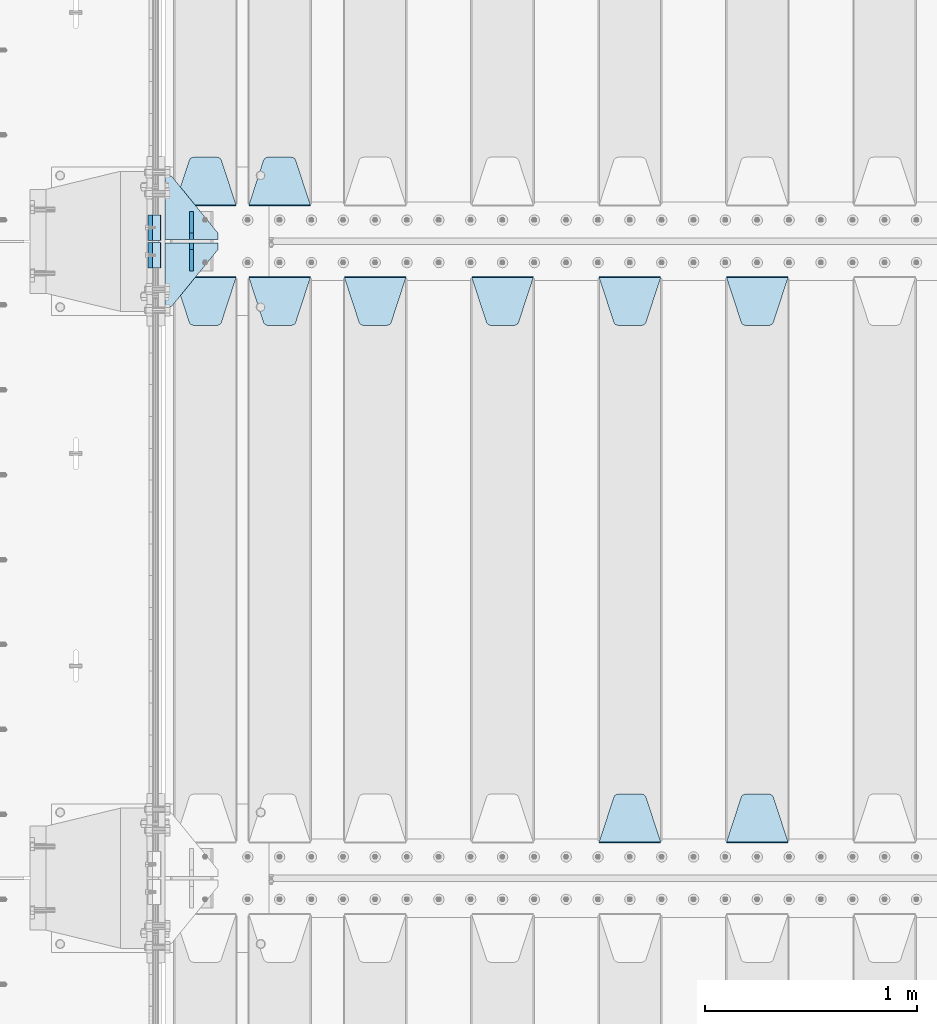
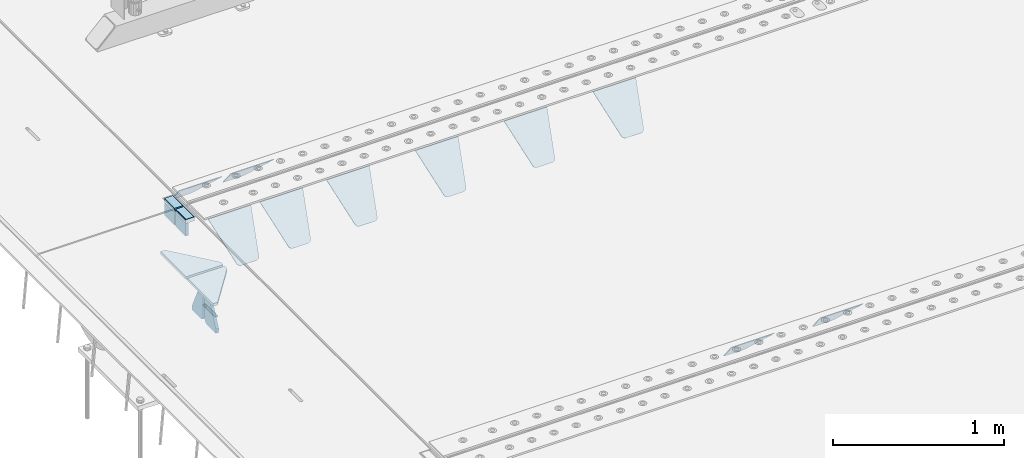
# One storey, part 178 of 219: 18 plates.
"""IFC2X3 building model written with IfcOpenShell, lengths in millimetres."""

import ifcopenshell
import ifcopenshell.guid

model = None  # the IFC model being written
_history = None  # IfcOwnerHistory: only IFC2X3 demands one
_inside = {}  # id of a spatial element -> (the spatial element, [elements in it])
_under = {}  # id of a project, library or spatial element -> (it, [spatial elements below it])
_declared = {}  # id of a project -> (the project, [libraries it declares])
_typed = {}  # id of a type object -> (the type object, [elements of that type])
_made_of = {}  # id of a material, layer set ... -> (it, [elements and type objects made of it])


def new_model(schema):
    """Start an empty IFC model of exactly this schema.

    Asked for "IFC4X3", IfcOpenShell would pick the latest addendum, in which some entities
    have other attributes; the version numbers below select the first issue.
    IFC2X3 requires an IfcOwnerHistory on every rooted entity: one is made here for all.
    """
    global model, _history
    if schema == "IFC4X3":
        model = ifcopenshell.file(schema_version=(4, 3, 0, 0))
    else:
        model = ifcopenshell.file(schema=schema)
    _inside.clear()
    _under.clear()
    _declared.clear()
    _typed.clear()
    _made_of.clear()
    _history = None
    if model.schema == "IFC2X3":
        org = make("IfcOrganization", Name="unknown")
        user = make(
            "IfcPersonAndOrganization",
            ThePerson=make("IfcPerson", FamilyName="unknown"),
            TheOrganization=org,
        )
        app = make(
            "IfcApplication",
            ApplicationDeveloper=org,
            Version="unknown",
            ApplicationFullName="unknown",
            ApplicationIdentifier="unknown",
        )
        _history = make(
            "IfcOwnerHistory",
            OwningUser=user,
            OwningApplication=app,
            ChangeAction="ADDED",
            CreationDate=0,
        )
    return model


def make(cls, **values):
    """One entity of the class cls with the attributes given. An attribute that is None is left unset."""
    return model.create_entity(
        cls, **{name: value for name, value in values.items() if value is not None}
    )


def rooted(cls, **values):
    """An entity with a GlobalId (a new one), such as an element, a storey or a relation."""
    return make(cls, GlobalId=ifcopenshell.guid.new(), OwnerHistory=_history, **values)


def si_unit(unit_type, name, prefix=None):
    """IfcSIUnit, for example si_unit("LENGTHUNIT", "METRE", prefix="MILLI")."""
    return make("IfcSIUnit", UnitType=unit_type, Prefix=prefix, Name=name)


def assignment(units):
    """IfcUnitAssignment: the units of a project."""
    return None if units is None else make("IfcUnitAssignment", Units=units)


def point(xyz):
    """IfcCartesianPoint."""
    return None if xyz is None else make("IfcCartesianPoint", Coordinates=xyz)


def direction(xyz):
    """IfcDirection."""
    return None if xyz is None else make("IfcDirection", DirectionRatios=xyz)


def frame(location, z_axis=None, x_axis=None):
    """IfcAxis2Placement3D, a coordinate frame: its origin and axes. An axis left out is left unset."""
    return make(
        "IfcAxis2Placement3D",
        Location=point(location),
        Axis=direction(z_axis),
        RefDirection=direction(x_axis),
    )


def origin_with_axes():
    """The frame at (0, 0, 0) with the z axis (0, 0, 1) and the x axis (1, 0, 0) written out."""
    return frame((0.0, 0.0, 0.0), z_axis=(0.0, 0.0, 1.0), x_axis=(1.0, 0.0, 0.0))


def place(relative_to, where):
    """IfcLocalPlacement: puts the frame where relative to a parent placement (None: the world)."""
    return make(
        "IfcLocalPlacement", PlacementRelTo=relative_to, RelativePlacement=where
    )


def context(
    kind, dimensions, precision=None, world=None, true_north=None, identifier=None
):
    """IfcGeometricRepresentationContext, for example the 3D "Model" context."""
    return make(
        "IfcGeometricRepresentationContext",
        ContextIdentifier=identifier,
        ContextType=kind,
        CoordinateSpaceDimension=dimensions,
        Precision=precision,
        WorldCoordinateSystem=world,
        TrueNorth=true_north,
    )


def subcontext(parent, identifier, kind, view, scale=None):
    """IfcGeometricRepresentationSubContext, for example "Body" below "Model"."""
    return make(
        "IfcGeometricRepresentationSubContext",
        ContextIdentifier=identifier,
        ContextType=kind,
        ParentContext=parent,
        TargetScale=scale,
        TargetView=view,
    )


def project(units=None, contexts=None):
    """IfcProject with its units and contexts."""
    return rooted(
        "IfcProject",
        Name="project",
        RepresentationContexts=contexts,
        UnitsInContext=assignment(units),
    )


def spatial(cls, under=None, at=None, **own):
    """A site, building, storey or space (cls), placed at a placement, below another one or the project."""
    s = rooted(cls, ObjectPlacement=at, **own)
    if under is not None:
        _under.setdefault(under.id(), (under, []))[1].append(s)
    return s


def faces_of(points, faces, orient=None, outer=None):
    """IfcFace entities. A face is a list of loops; a loop is a list of indices into points, from 0.

    orient and outer hold one flag for each loop. By default every Orientation is true, the
    first loop of a face is its IfcFaceOuterBound and the others are IfcFaceBound.
    """
    made = []
    for i, loops in enumerate(faces):
        bounds = []
        for j, loop in enumerate(loops):
            is_outer = j == 0 if outer is None else outer[i][j]
            bounds.append(
                make(
                    "IfcFaceOuterBound" if is_outer else "IfcFaceBound",
                    Bound=make("IfcPolyLoop", Polygon=[points[k] for k in loop]),
                    Orientation=True if orient is None else orient[i][j],
                )
            )
        made.append(make("IfcFace", Bounds=bounds))
    return made


def faceted_brep(points, faces, orient=None, outer=None, voids=None):
    """IfcFacetedBrep: a solid bounded by flat faces; with voids (closed shells), ...WithVoids."""
    shared = [point(p) for p in points]
    hull = make("IfcClosedShell", CfsFaces=faces_of(shared, faces, orient, outer))
    if voids is None:
        return make("IfcFacetedBrep", Outer=hull)
    return make(
        "IfcFacetedBrepWithVoids",
        Outer=hull,
        Voids=[
            make(cls, CfsFaces=faces_of(shared, fs, o, b)) for cls, fs, o, b in voids
        ],
    )


def shape(context_of_items, identifier, shape_type, items):
    """IfcShapeRepresentation: the items that make up one representation, for example the "Body"."""
    return make(
        "IfcShapeRepresentation",
        ContextOfItems=context_of_items,
        RepresentationIdentifier=identifier,
        RepresentationType=shape_type,
        Items=items,
    )


def material(Name=None, Category=None):
    """IfcMaterial."""
    return make("IfcMaterial", Name=Name, Category=Category)


def made_of(thing, what):
    """Note that an element or type object is made of a material, layer set ...; save() writes the relation."""
    if what is not None:
        _made_of.setdefault(what.id(), (what, []))[1].append(thing)
    return thing


def type_object(cls, material=None, **own):
    """A type object (cls), such as IfcWallType, which elements share."""
    return made_of(rooted(cls, **own), material)


def element(
    cls,
    number,
    at=None,
    inside=None,
    cuts=None,
    type_object=None,
    material=None,
    context=None,
    identifier="Body",
    shape_type=None,
    held_by="IfcProductDefinitionShape",
    body=None,
    shapes=None,
    **own,
):
    """One element of the class cls, such as IfcWall. Its Tag is "e" and its number.

    at: its placement. inside: the storey or other place that contains it. cuts: it is an
    opening in that element (IfcRelVoidsElement). A single representation is given by context,
    identifier, shape_type and body (its items); several are given by shapes. held_by: the class
    of the entity that holds the representations. save() writes the other relations.
    """
    e = rooted(cls, Tag="e%d" % number, ObjectPlacement=at, **own)
    if body is not None:
        shapes = [shape(context, identifier, shape_type, body)]
    if shapes is not None:
        e.Representation = make(held_by, Representations=shapes)
    if inside is not None:
        _inside.setdefault(inside.id(), (inside, []))[1].append(e)
    if cuts is not None:
        rooted(
            "IfcRelVoidsElement", RelatingBuildingElement=cuts, RelatedOpeningElement=e
        )
    if type_object is not None:
        _typed.setdefault(type_object.id(), (type_object, []))[1].append(e)
    return made_of(e, material)


def aggregate(whole, parts):
    """IfcRelAggregates: a whole, such as a stair, and the parts it consists of."""
    return rooted("IfcRelAggregates", RelatingObject=whole, RelatedObjects=parts)


def save(model, path):
    """Write the relations noted so far, then the file.

    IfcRelAggregates (storeys below a building ...), IfcRelContainedInSpatialStructure (elements
    in a storey), IfcRelDefinesByType, IfcRelAssociatesMaterial and IfcRelDeclares: one each for
    every whole, place, type object, material and project.
    """
    for whole, parts in _under.values():
        aggregate(whole, parts)
    for where, things in _inside.values():
        rooted(
            "IfcRelContainedInSpatialStructure",
            RelatedElements=things,
            RelatingStructure=where,
        )
    for kind, things in _typed.values():
        rooted("IfcRelDefinesByType", RelatedObjects=things, RelatingType=kind)
    for what, things in _made_of.values():
        rooted("IfcRelAssociatesMaterial", RelatedObjects=things, RelatingMaterial=what)
    for by, libraries in _declared.values():
        rooted("IfcRelDeclares", RelatingContext=by, RelatedDefinitions=libraries)
    model.write(path)


model = new_model("IFC2X3")

# Units and contexts
model_context = context("Model", 3, precision=1e-05, world=origin_with_axes())
body_context = subcontext(model_context, "Body", "Model", "MODEL_VIEW")
ifc_project = project(units=[si_unit("LENGTHUNIT", "METRE", prefix="MILLI"), si_unit("AREAUNIT", "SQUARE_METRE"), si_unit("VOLUMEUNIT", "CUBIC_METRE"), si_unit("MASSUNIT", "GRAM", prefix="KILO"), si_unit("TIMEUNIT", "SECOND"), si_unit("PLANEANGLEUNIT", "RADIAN"), si_unit("SOLIDANGLEUNIT", "STERADIAN"), si_unit("THERMODYNAMICTEMPERATUREUNIT", "DEGREE_CELSIUS"), si_unit("LUMINOUSINTENSITYUNIT", "LUMEN")], contexts=[model_context])

# Site, building, storey
site_placement = place(None, origin_with_axes())
site = spatial("IfcSite", under=ifc_project, at=site_placement, CompositionType="ELEMENT")
building_placement = place(site_placement, origin_with_axes())
building = spatial("IfcBuilding", under=site, at=building_placement, Name="Standard", CompositionType="ELEMENT")
storey_placement = place(building_placement, origin_with_axes())
storey = spatial("IfcBuildingStorey", under=building, at=storey_placement, Name="Undefined", CompositionType="ELEMENT", Elevation=0.0)

# Plates
ifc_material_1 = material()
plate_type_1 = type_object("IfcPlateType", PredefinedType="NOTDEFINED")
for number, where, z_axis, x_axis in (
    (1, (-9.99999993997335, 29935.0000004336, -16.000386849525), (-1.0, 0.0, 0.0), (0.0, -4.95099997756316e-06, 0.999999999987744)),
    (2, (-10.0000000600267, 30065.0000004319, -15.9997432191214), (-1.0, 0.0, 0.0), (0.0, -4.95099997756316e-06, 0.999999999987744)),
):
    element("IfcPlate", number, at=place(storey_placement, frame(where, z_axis=z_axis, x_axis=x_axis)), inside=storey, type_object=plate_type_1, material=ifc_material_1, context=body_context, shape_type="Brep", body=[
        faceted_brep([(0.0, -60.0, 0.0), (-0.000933120085687023, -60.0000000000036, 60.0), (-0.000933120085687023, 59.9999999999964, 60.0), (0.0, 60.0000000000036, 0.0), (24.9991450303709, -60.0, 60.0), (24.9991450303709, 59.9999999999964, 60.0), (26.544215218168, -60.0000000000036, 59.7552873850884), (26.544215218168, 60.0, 59.7552873850884), (27.9380461396139, -60.0000000000036, 59.0451032459123), (27.9380461396139, 60.0, 59.0451032459123), (29.0442025908961, -60.0000000000036, 57.9389639895784), (29.0442025908961, 60.0, 57.9389639895784), (29.7544083969366, -60.0, 56.5451441080361), (29.7544083969366, 60.0000000000036, 56.5451441080361), (29.9991450297669, -60.0000000000036, 55.0000777244568), (29.9991450297669, 60.0, 55.0000777244568), (29.999922274335, -60.0, 5.00007772445704), (29.999922274335, 60.0, 5.00007772445704), (29.7552240705896, -60.0000000000036, 3.45497416452589), (29.7552240705896, 60.0, 3.45497416452589), (29.0450346578116, -60.0, 2.06111146690959), (29.0450346578116, 59.9999999999964, 2.06111146690959), (27.9388736885072, -60.0, 0.954933302319514), (27.9388736885072, 59.9999999999964, 0.954933302319514), (26.5450220308766, -60.0000000000036, 0.244722222183089), (26.5450220308766, 60.0, 0.244722222183089), (24.9999222749392, -60.0, 2.64677169070637e-13), (24.9999222749392, 60.0, 2.66453525910038e-13)], [[[0, 1, 2, 3]], [[1, 4, 5, 2]], [[4, 6, 7, 5]], [[6, 8, 9, 7]], [[8, 10, 11, 9]], [[10, 12, 13, 11]], [[12, 14, 15, 13]], [[14, 16, 17, 15]], [[16, 18, 19, 17]], [[18, 20, 21, 19]], [[20, 22, 23, 21]], [[22, 24, 25, 23]], [[24, 26, 27, 25]], [[26, 0, 3, 27]], [[5, 7, 9, 11, 13, 15, 17, 19, 21, 23, 25, 27, 3, 2]], [[26, 24, 22, 20, 18, 16, 14, 12, 10, 8, 6, 4, 1, 0]]]),
    ])
ifc_material_2 = material(Name="STEEL/S355N")
plate_type_2 = type_object("IfcPlateType", PredefinedType="NOTDEFINED")
for number, where, z_axis, x_axis in (
    (3, (-60.0, 29995.0004459832, -106.000711879208), (0.0, -0.999999999987744, -4.95099999993769e-06), (0.0, -4.95099997756316e-06, 0.999999999987744)),
    (4, (-60.0, 30125.0004459814, -106.000068249326), (0.0, -0.999999999987744, -4.95099999993769e-06), (0.0, -4.95099997756316e-06, 0.999999999987744)),
):
    element("IfcPlate", number, at=place(storey_placement, frame(where, z_axis=z_axis, x_axis=x_axis)), inside=storey, type_object=plate_type_2, material=ifc_material_2, context=body_context, shape_type="Brep", body=[
        faceted_brep([(0.0, -10.0, 0.0), (4.30816271546064e-10, -10.0, 120.000000000004), (4.30816271546064e-10, 10.0, 120.000000000004), (0.0, 10.0, 0.0), (89.9999999999979, -10.0, 120.000000000004), (89.9999999999979, 10.0, 120.000000000004), (90.0, -10.0, 1.09139364212751e-11), (90.0, 10.0, 1.09139364212751e-11)], [[[0, 1, 2, 3]], [[1, 4, 5, 2]], [[4, 6, 7, 5]], [[6, 0, 3, 7]], [[5, 7, 3, 2]], [[6, 4, 1, 0]]]),
    ])
plate_type_3 = type_object("IfcPlateType", PredefinedType="NOTDEFINED")
plate_1_placement = place(storey_placement, frame((2655.0, 29831.767766956, -1.76776695296758), z_axis=(0.0, -0.707106781186547, -0.707106781186548), x_axis=(1.0, 0.0, 0.0)))
element("IfcPlate", 5, at=plate_1_placement, inside=storey, type_object=plate_type_3, material=ifc_material_2, context=body_context, shape_type="Brep", body=[
    faceted_brep([(0.0, -2.5, 0.0), (69.345504679477, -2.5, 300.171731424834), (69.345504679477, 2.49999999999636, 300.171731424831), (0.0, 2.5, 0.0), (70.9274061199576, -2.50000000000364, 304.8974424154), (70.9274061199576, 2.49999999999636, 304.8974424154), (73.3818627772307, -2.50000000000364, 309.234538108532), (73.3818627772307, 2.49999999999636, 309.234538108532), (76.6187032999569, -2.50000000000364, 313.023683126106), (76.6187032999569, 2.49999999999636, 313.023683126106), (80.5190132704993, -2.50000000000364, 316.125672595372), (80.5190132704993, 2.49999999999636, 316.125672595372), (84.9395038596831, -2.50000000000364, 318.426546230476), (84.9395038596831, 2.5, 318.426546230479), (89.7177759439237, -2.50000000000364, 319.841774983277), (89.7177759439237, 2.5, 319.841774983281), (94.6782862926502, -2.50000000000364, 320.319366455078), (94.6782862926502, 2.49999999999636, 320.319366455078), (195.32171370735, -2.50000000000364, 320.319366455078), (195.32171370735, 2.49999999999636, 320.319366455078), (200.282224056076, -2.50000000000364, 319.841774983277), (200.282224056076, 2.5, 319.841774983281), (205.060496140317, -2.50000000000364, 318.426546230476), (205.060496140317, 2.49999999999636, 318.426546230476), (209.480986729501, -2.50000000000364, 316.125672595372), (209.480986729501, 2.49999999999636, 316.125672595372), (213.381296700043, -2.50000000000364, 313.023683126106), (213.381296700043, 2.49999999999272, 313.023683126106), (216.618137222769, -2.50000000000364, 309.234538108529), (216.618137222769, 2.49999999999636, 309.234538108525), (219.072593880042, -2.50000000000364, 304.8974424154), (219.072593880042, 2.49999999999636, 304.8974424154), (220.654495320523, -2.5, 300.171731424834), (220.654495320523, 2.49999999999636, 300.171731424831), (290.0, -2.50000000000364, 3.63797880709171e-12), (290.0, 2.49999999999636, 0.0)], [[[0, 1, 2, 3]], [[1, 4, 5, 2]], [[4, 6, 7, 5]], [[6, 8, 9, 7]], [[8, 10, 11, 9]], [[10, 12, 13, 11]], [[12, 14, 15, 13]], [[14, 16, 17, 15]], [[16, 18, 19, 17]], [[18, 20, 21, 19]], [[20, 22, 23, 21]], [[22, 24, 25, 23]], [[24, 26, 27, 25]], [[26, 28, 29, 27]], [[28, 30, 31, 29]], [[30, 32, 33, 31]], [[32, 34, 35, 33]], [[34, 0, 3, 35]], [[5, 7, 9, 11, 13, 15, 17, 19, 21, 23, 25, 27, 29, 31, 33, 35, 3, 2]], [[34, 32, 30, 28, 26, 24, 22, 20, 18, 16, 14, 12, 10, 8, 6, 4, 1, 0]]]),
])
plate_2_placement = place(storey_placement, frame((2945.0, 27168.232233047, -1.76776695296758), z_axis=(0.0, 0.707106781186547, -0.707106781186548), x_axis=(-1.0, 0.0, 0.0)))
element("IfcPlate", 6, at=plate_2_placement, inside=storey, type_object=plate_type_3, material=ifc_material_2, context=body_context, shape_type="Brep", body=[
    faceted_brep([(0.0, -2.5, 0.0), (69.345504679477, -2.5, 300.171731424834), (69.345504679477, 2.49999999999636, 300.171731424831), (0.0, 2.5, 0.0), (70.9274061199576, -2.50000000000364, 304.8974424154), (70.9274061199576, 2.49999999999636, 304.8974424154), (73.3818627772307, -2.50000000000364, 309.234538108532), (73.3818627772307, 2.49999999999636, 309.234538108532), (76.6187032999569, -2.50000000000364, 313.023683126106), (76.6187032999569, 2.49999999999636, 313.023683126106), (80.5190132704993, -2.50000000000364, 316.125672595372), (80.5190132704993, 2.49999999999636, 316.125672595372), (84.9395038596831, -2.50000000000364, 318.426546230476), (84.9395038596831, 2.5, 318.426546230479), (89.7177759439237, -2.50000000000364, 319.841774983277), (89.7177759439237, 2.5, 319.841774983281), (94.6782862926502, -2.50000000000364, 320.319366455078), (94.6782862926502, 2.49999999999636, 320.319366455078), (195.32171370735, -2.50000000000364, 320.319366455078), (195.32171370735, 2.49999999999636, 320.319366455078), (200.282224056076, -2.50000000000364, 319.841774983277), (200.282224056076, 2.5, 319.841774983281), (205.060496140317, -2.50000000000364, 318.426546230476), (205.060496140317, 2.49999999999636, 318.426546230476), (209.480986729501, -2.50000000000364, 316.125672595372), (209.480986729501, 2.49999999999636, 316.125672595372), (213.381296700043, -2.50000000000364, 313.023683126106), (213.381296700043, 2.49999999999272, 313.023683126106), (216.618137222769, -2.50000000000364, 309.234538108529), (216.618137222769, 2.49999999999636, 309.234538108525), (219.072593880042, -2.50000000000364, 304.8974424154), (219.072593880042, 2.49999999999636, 304.8974424154), (220.654495320523, -2.5, 300.171731424834), (220.654495320523, 2.49999999999636, 300.171731424831), (290.0, -2.50000000000364, 3.63797880709171e-12), (290.0, 2.49999999999636, 0.0)], [[[0, 1, 2, 3]], [[1, 4, 5, 2]], [[4, 6, 7, 5]], [[6, 8, 9, 7]], [[8, 10, 11, 9]], [[10, 12, 13, 11]], [[12, 14, 15, 13]], [[14, 16, 17, 15]], [[16, 18, 19, 17]], [[18, 20, 21, 19]], [[20, 22, 23, 21]], [[22, 24, 25, 23]], [[24, 26, 27, 25]], [[26, 28, 29, 27]], [[28, 30, 31, 29]], [[30, 32, 33, 31]], [[32, 34, 35, 33]], [[34, 0, 3, 35]], [[5, 7, 9, 11, 13, 15, 17, 19, 21, 23, 25, 27, 29, 31, 33, 35, 3, 2]], [[34, 32, 30, 28, 26, 24, 22, 20, 18, 16, 14, 12, 10, 8, 6, 4, 1, 0]]]),
])
plate_3_placement = place(storey_placement, frame((2055.0, 29831.767766956, -1.76776695296758), z_axis=(0.0, -0.707106781186547, -0.707106781186548), x_axis=(1.0, 0.0, 0.0)))
element("IfcPlate", 7, at=plate_3_placement, inside=storey, type_object=plate_type_3, material=ifc_material_2, context=body_context, shape_type="Brep", body=[
    faceted_brep([(0.0, -2.5, 0.0), (69.345504679477, -2.5, 300.171731424834), (69.345504679477, 2.49999999999636, 300.171731424831), (0.0, 2.5, 0.0), (70.9274061199576, -2.50000000000364, 304.8974424154), (70.9274061199576, 2.49999999999636, 304.8974424154), (73.3818627772307, -2.50000000000364, 309.234538108532), (73.3818627772307, 2.49999999999636, 309.234538108532), (76.6187032999569, -2.50000000000364, 313.023683126106), (76.6187032999569, 2.49999999999636, 313.023683126106), (80.5190132704993, -2.50000000000364, 316.125672595372), (80.5190132704993, 2.49999999999636, 316.125672595372), (84.9395038596831, -2.50000000000364, 318.426546230476), (84.9395038596831, 2.5, 318.426546230479), (89.7177759439237, -2.50000000000364, 319.841774983277), (89.7177759439237, 2.5, 319.841774983281), (94.6782862926502, -2.50000000000364, 320.319366455078), (94.6782862926502, 2.49999999999636, 320.319366455078), (195.32171370735, -2.50000000000364, 320.319366455078), (195.32171370735, 2.49999999999636, 320.319366455078), (200.282224056076, -2.50000000000364, 319.841774983277), (200.282224056076, 2.5, 319.841774983281), (205.060496140317, -2.50000000000364, 318.426546230476), (205.060496140317, 2.49999999999636, 318.426546230476), (209.480986729501, -2.50000000000364, 316.125672595372), (209.480986729501, 2.49999999999636, 316.125672595372), (213.381296700043, -2.50000000000364, 313.023683126106), (213.381296700043, 2.49999999999272, 313.023683126106), (216.618137222769, -2.50000000000364, 309.234538108529), (216.618137222769, 2.49999999999636, 309.234538108525), (219.072593880042, -2.50000000000364, 304.8974424154), (219.072593880042, 2.49999999999636, 304.8974424154), (220.654495320523, -2.5, 300.171731424834), (220.654495320523, 2.49999999999636, 300.171731424831), (290.0, -2.50000000000364, 3.63797880709171e-12), (290.0, 2.49999999999636, 0.0)], [[[0, 1, 2, 3]], [[1, 4, 5, 2]], [[4, 6, 7, 5]], [[6, 8, 9, 7]], [[8, 10, 11, 9]], [[10, 12, 13, 11]], [[12, 14, 15, 13]], [[14, 16, 17, 15]], [[16, 18, 19, 17]], [[18, 20, 21, 19]], [[20, 22, 23, 21]], [[22, 24, 25, 23]], [[24, 26, 27, 25]], [[26, 28, 29, 27]], [[28, 30, 31, 29]], [[30, 32, 33, 31]], [[32, 34, 35, 33]], [[34, 0, 3, 35]], [[5, 7, 9, 11, 13, 15, 17, 19, 21, 23, 25, 27, 29, 31, 33, 35, 3, 2]], [[34, 32, 30, 28, 26, 24, 22, 20, 18, 16, 14, 12, 10, 8, 6, 4, 1, 0]]]),
])
plate_4_placement = place(storey_placement, frame((2345.0, 27168.232233047, -1.76776695296758), z_axis=(0.0, 0.707106781186547, -0.707106781186548), x_axis=(-1.0, 0.0, 0.0)))
element("IfcPlate", 8, at=plate_4_placement, inside=storey, type_object=plate_type_3, material=ifc_material_2, context=body_context, shape_type="Brep", body=[
    faceted_brep([(0.0, -2.5, 0.0), (69.345504679477, -2.5, 300.171731424834), (69.345504679477, 2.49999999999636, 300.171731424831), (0.0, 2.5, 0.0), (70.9274061199576, -2.50000000000364, 304.8974424154), (70.9274061199576, 2.49999999999636, 304.8974424154), (73.3818627772307, -2.50000000000364, 309.234538108532), (73.3818627772307, 2.49999999999636, 309.234538108532), (76.6187032999569, -2.50000000000364, 313.023683126106), (76.6187032999569, 2.49999999999636, 313.023683126106), (80.5190132704993, -2.50000000000364, 316.125672595372), (80.5190132704993, 2.49999999999636, 316.125672595372), (84.9395038596831, -2.50000000000364, 318.426546230476), (84.9395038596831, 2.5, 318.426546230479), (89.7177759439237, -2.50000000000364, 319.841774983277), (89.7177759439237, 2.5, 319.841774983281), (94.6782862926502, -2.50000000000364, 320.319366455078), (94.6782862926502, 2.49999999999636, 320.319366455078), (195.32171370735, -2.50000000000364, 320.319366455078), (195.32171370735, 2.49999999999636, 320.319366455078), (200.282224056076, -2.50000000000364, 319.841774983277), (200.282224056076, 2.5, 319.841774983281), (205.060496140317, -2.50000000000364, 318.426546230476), (205.060496140317, 2.49999999999636, 318.426546230476), (209.480986729501, -2.50000000000364, 316.125672595372), (209.480986729501, 2.49999999999636, 316.125672595372), (213.381296700043, -2.50000000000364, 313.023683126106), (213.381296700043, 2.49999999999272, 313.023683126106), (216.618137222769, -2.50000000000364, 309.234538108529), (216.618137222769, 2.49999999999636, 309.234538108525), (219.072593880042, -2.50000000000364, 304.8974424154), (219.072593880042, 2.49999999999636, 304.8974424154), (220.654495320523, -2.5, 300.171731424834), (220.654495320523, 2.49999999999636, 300.171731424831), (290.0, -2.50000000000364, 3.63797880709171e-12), (290.0, 2.49999999999636, 0.0)], [[[0, 1, 2, 3]], [[1, 4, 5, 2]], [[4, 6, 7, 5]], [[6, 8, 9, 7]], [[8, 10, 11, 9]], [[10, 12, 13, 11]], [[12, 14, 15, 13]], [[14, 16, 17, 15]], [[16, 18, 19, 17]], [[18, 20, 21, 19]], [[20, 22, 23, 21]], [[22, 24, 25, 23]], [[24, 26, 27, 25]], [[26, 28, 29, 27]], [[28, 30, 31, 29]], [[30, 32, 33, 31]], [[32, 34, 35, 33]], [[34, 0, 3, 35]], [[5, 7, 9, 11, 13, 15, 17, 19, 21, 23, 25, 27, 29, 31, 33, 35, 3, 2]], [[34, 32, 30, 28, 26, 24, 22, 20, 18, 16, 14, 12, 10, 8, 6, 4, 1, 0]]]),
])
plate_5_placement = place(storey_placement, frame((1455.0, 29831.767766956, -1.76776695296758), z_axis=(0.0, -0.707106781186547, -0.707106781186548), x_axis=(1.0, 0.0, 0.0)))
element("IfcPlate", 9, at=plate_5_placement, inside=storey, type_object=plate_type_3, material=ifc_material_2, context=body_context, shape_type="Brep", body=[
    faceted_brep([(0.0, -2.5, 0.0), (69.345504679477, -2.5, 300.171731424834), (69.345504679477, 2.49999999999636, 300.171731424831), (0.0, 2.5, 0.0), (70.9274061199576, -2.50000000000364, 304.8974424154), (70.9274061199576, 2.49999999999636, 304.8974424154), (73.3818627772307, -2.50000000000364, 309.234538108532), (73.3818627772307, 2.49999999999636, 309.234538108532), (76.6187032999569, -2.50000000000364, 313.023683126106), (76.6187032999569, 2.49999999999636, 313.023683126106), (80.5190132704993, -2.50000000000364, 316.125672595372), (80.5190132704993, 2.49999999999636, 316.125672595372), (84.9395038596831, -2.50000000000364, 318.426546230476), (84.9395038596831, 2.5, 318.426546230479), (89.7177759439237, -2.50000000000364, 319.841774983277), (89.7177759439237, 2.5, 319.841774983281), (94.6782862926502, -2.50000000000364, 320.319366455078), (94.6782862926502, 2.49999999999636, 320.319366455078), (195.32171370735, -2.50000000000364, 320.319366455078), (195.32171370735, 2.49999999999636, 320.319366455078), (200.282224056076, -2.50000000000364, 319.841774983277), (200.282224056076, 2.5, 319.841774983281), (205.060496140317, -2.50000000000364, 318.426546230476), (205.060496140317, 2.49999999999636, 318.426546230476), (209.480986729501, -2.50000000000364, 316.125672595372), (209.480986729501, 2.49999999999636, 316.125672595372), (213.381296700043, -2.50000000000364, 313.023683126106), (213.381296700043, 2.49999999999272, 313.023683126106), (216.618137222769, -2.50000000000364, 309.234538108529), (216.618137222769, 2.49999999999636, 309.234538108525), (219.072593880042, -2.50000000000364, 304.8974424154), (219.072593880042, 2.49999999999636, 304.8974424154), (220.654495320523, -2.5, 300.171731424834), (220.654495320523, 2.49999999999636, 300.171731424831), (290.0, -2.50000000000364, 3.63797880709171e-12), (290.0, 2.49999999999636, 0.0)], [[[0, 1, 2, 3]], [[1, 4, 5, 2]], [[4, 6, 7, 5]], [[6, 8, 9, 7]], [[8, 10, 11, 9]], [[10, 12, 13, 11]], [[12, 14, 15, 13]], [[14, 16, 17, 15]], [[16, 18, 19, 17]], [[18, 20, 21, 19]], [[20, 22, 23, 21]], [[22, 24, 25, 23]], [[24, 26, 27, 25]], [[26, 28, 29, 27]], [[28, 30, 31, 29]], [[30, 32, 33, 31]], [[32, 34, 35, 33]], [[34, 0, 3, 35]], [[5, 7, 9, 11, 13, 15, 17, 19, 21, 23, 25, 27, 29, 31, 33, 35, 3, 2]], [[34, 32, 30, 28, 26, 24, 22, 20, 18, 16, 14, 12, 10, 8, 6, 4, 1, 0]]]),
])
plate_6_placement = place(storey_placement, frame((855.0, 29831.767766956, -1.76776695296758), z_axis=(0.0, -0.707106781186547, -0.707106781186548), x_axis=(1.0, 0.0, 0.0)))
element("IfcPlate", 10, at=plate_6_placement, inside=storey, type_object=plate_type_3, material=ifc_material_2, context=body_context, shape_type="Brep", body=[
    faceted_brep([(0.0, -2.5, 0.0), (69.345504679477, -2.5, 300.171731424834), (69.345504679477, 2.49999999999636, 300.171731424831), (0.0, 2.5, 0.0), (70.9274061199576, -2.50000000000364, 304.8974424154), (70.9274061199576, 2.49999999999636, 304.8974424154), (73.3818627772307, -2.50000000000364, 309.234538108532), (73.3818627772307, 2.49999999999636, 309.234538108532), (76.6187032999569, -2.50000000000364, 313.023683126106), (76.6187032999569, 2.49999999999636, 313.023683126106), (80.5190132704993, -2.50000000000364, 316.125672595372), (80.5190132704993, 2.49999999999636, 316.125672595372), (84.9395038596831, -2.50000000000364, 318.426546230476), (84.9395038596831, 2.5, 318.426546230479), (89.7177759439237, -2.50000000000364, 319.841774983277), (89.7177759439237, 2.5, 319.841774983281), (94.6782862926502, -2.50000000000364, 320.319366455078), (94.6782862926502, 2.49999999999636, 320.319366455078), (195.32171370735, -2.50000000000364, 320.319366455078), (195.32171370735, 2.49999999999636, 320.319366455078), (200.282224056076, -2.50000000000364, 319.841774983277), (200.282224056076, 2.5, 319.841774983281), (205.060496140317, -2.50000000000364, 318.426546230476), (205.060496140317, 2.49999999999636, 318.426546230476), (209.480986729501, -2.50000000000364, 316.125672595372), (209.480986729501, 2.49999999999636, 316.125672595372), (213.381296700043, -2.50000000000364, 313.023683126106), (213.381296700043, 2.49999999999272, 313.023683126106), (216.618137222769, -2.50000000000364, 309.234538108529), (216.618137222769, 2.49999999999636, 309.234538108525), (219.072593880042, -2.50000000000364, 304.8974424154), (219.072593880042, 2.49999999999636, 304.8974424154), (220.654495320523, -2.5, 300.171731424834), (220.654495320523, 2.49999999999636, 300.171731424831), (290.0, -2.50000000000364, 3.63797880709171e-12), (290.0, 2.49999999999636, 0.0)], [[[0, 1, 2, 3]], [[1, 4, 5, 2]], [[4, 6, 7, 5]], [[6, 8, 9, 7]], [[8, 10, 11, 9]], [[10, 12, 13, 11]], [[12, 14, 15, 13]], [[14, 16, 17, 15]], [[16, 18, 19, 17]], [[18, 20, 21, 19]], [[20, 22, 23, 21]], [[22, 24, 25, 23]], [[24, 26, 27, 25]], [[26, 28, 29, 27]], [[28, 30, 31, 29]], [[30, 32, 33, 31]], [[32, 34, 35, 33]], [[34, 0, 3, 35]], [[5, 7, 9, 11, 13, 15, 17, 19, 21, 23, 25, 27, 29, 31, 33, 35, 3, 2]], [[34, 32, 30, 28, 26, 24, 22, 20, 18, 16, 14, 12, 10, 8, 6, 4, 1, 0]]]),
])
plate_7_placement = place(storey_placement, frame((405.0, 29831.767766956, -1.76776695296758), z_axis=(0.0, -0.707106781186547, -0.707106781186548), x_axis=(1.0, 0.0, 0.0)))
element("IfcPlate", 11, at=plate_7_placement, inside=storey, type_object=plate_type_3, material=ifc_material_2, context=body_context, shape_type="Brep", body=[
    faceted_brep([(0.0, -2.5, 0.0), (69.345504679477, -2.5, 300.171731424834), (69.345504679477, 2.49999999999636, 300.171731424831), (0.0, 2.5, 0.0), (70.9274061199576, -2.50000000000364, 304.8974424154), (70.9274061199576, 2.49999999999636, 304.8974424154), (73.3818627772307, -2.50000000000364, 309.234538108532), (73.3818627772307, 2.49999999999636, 309.234538108532), (76.6187032999569, -2.50000000000364, 313.023683126106), (76.6187032999569, 2.49999999999636, 313.023683126106), (80.5190132704993, -2.50000000000364, 316.125672595372), (80.5190132704993, 2.49999999999636, 316.125672595372), (84.9395038596831, -2.50000000000364, 318.426546230476), (84.9395038596831, 2.5, 318.426546230479), (89.7177759439237, -2.50000000000364, 319.841774983277), (89.7177759439237, 2.5, 319.841774983281), (94.6782862926502, -2.50000000000364, 320.319366455078), (94.6782862926502, 2.49999999999636, 320.319366455078), (195.32171370735, -2.50000000000364, 320.319366455078), (195.32171370735, 2.49999999999636, 320.319366455078), (200.282224056076, -2.50000000000364, 319.841774983277), (200.282224056076, 2.5, 319.841774983281), (205.060496140317, -2.50000000000364, 318.426546230476), (205.060496140317, 2.49999999999636, 318.426546230476), (209.480986729501, -2.50000000000364, 316.125672595372), (209.480986729501, 2.49999999999636, 316.125672595372), (213.381296700043, -2.50000000000364, 313.023683126106), (213.381296700043, 2.49999999999272, 313.023683126106), (216.618137222769, -2.50000000000364, 309.234538108529), (216.618137222769, 2.49999999999636, 309.234538108525), (219.072593880042, -2.50000000000364, 304.8974424154), (219.072593880042, 2.49999999999636, 304.8974424154), (220.654495320523, -2.5, 300.171731424834), (220.654495320523, 2.49999999999636, 300.171731424831), (290.0, -2.50000000000364, 3.63797880709171e-12), (290.0, 2.49999999999636, 0.0)], [[[0, 1, 2, 3]], [[1, 4, 5, 2]], [[4, 6, 7, 5]], [[6, 8, 9, 7]], [[8, 10, 11, 9]], [[10, 12, 13, 11]], [[12, 14, 15, 13]], [[14, 16, 17, 15]], [[16, 18, 19, 17]], [[18, 20, 21, 19]], [[20, 22, 23, 21]], [[22, 24, 25, 23]], [[24, 26, 27, 25]], [[26, 28, 29, 27]], [[28, 30, 31, 29]], [[30, 32, 33, 31]], [[32, 34, 35, 33]], [[34, 0, 3, 35]], [[5, 7, 9, 11, 13, 15, 17, 19, 21, 23, 25, 27, 29, 31, 33, 35, 3, 2]], [[34, 32, 30, 28, 26, 24, 22, 20, 18, 16, 14, 12, 10, 8, 6, 4, 1, 0]]]),
])
plate_8_placement = place(storey_placement, frame((695.0, 30168.232233047, -1.76776695296758), z_axis=(0.0, 0.707106781186547, -0.707106781186548), x_axis=(-1.0, 0.0, 0.0)))
element("IfcPlate", 12, at=plate_8_placement, inside=storey, type_object=plate_type_3, material=ifc_material_2, context=body_context, shape_type="Brep", body=[
    faceted_brep([(0.0, -2.5, 0.0), (69.345504679477, -2.5, 300.171731424834), (69.345504679477, 2.49999999999636, 300.171731424831), (0.0, 2.5, 0.0), (70.9274061199576, -2.50000000000364, 304.8974424154), (70.9274061199576, 2.49999999999636, 304.8974424154), (73.3818627772307, -2.50000000000364, 309.234538108532), (73.3818627772307, 2.49999999999636, 309.234538108532), (76.6187032999569, -2.50000000000364, 313.023683126106), (76.6187032999569, 2.49999999999636, 313.023683126106), (80.5190132704993, -2.50000000000364, 316.125672595372), (80.5190132704993, 2.49999999999636, 316.125672595372), (84.9395038596831, -2.50000000000364, 318.426546230476), (84.9395038596831, 2.5, 318.426546230479), (89.7177759439237, -2.50000000000364, 319.841774983277), (89.7177759439237, 2.5, 319.841774983281), (94.6782862926502, -2.50000000000364, 320.319366455078), (94.6782862926502, 2.49999999999636, 320.319366455078), (195.32171370735, -2.50000000000364, 320.319366455078), (195.32171370735, 2.49999999999636, 320.319366455078), (200.282224056076, -2.50000000000364, 319.841774983277), (200.282224056076, 2.5, 319.841774983281), (205.060496140317, -2.50000000000364, 318.426546230476), (205.060496140317, 2.49999999999636, 318.426546230476), (209.480986729501, -2.50000000000364, 316.125672595372), (209.480986729501, 2.49999999999636, 316.125672595372), (213.381296700043, -2.50000000000364, 313.023683126106), (213.381296700043, 2.49999999999272, 313.023683126106), (216.618137222769, -2.50000000000364, 309.234538108529), (216.618137222769, 2.49999999999636, 309.234538108525), (219.072593880042, -2.50000000000364, 304.8974424154), (219.072593880042, 2.49999999999636, 304.8974424154), (220.654495320523, -2.5, 300.171731424834), (220.654495320523, 2.49999999999636, 300.171731424831), (290.0, -2.50000000000364, 3.63797880709171e-12), (290.0, 2.49999999999636, 0.0)], [[[0, 1, 2, 3]], [[1, 4, 5, 2]], [[4, 6, 7, 5]], [[6, 8, 9, 7]], [[8, 10, 11, 9]], [[10, 12, 13, 11]], [[12, 14, 15, 13]], [[14, 16, 17, 15]], [[16, 18, 19, 17]], [[18, 20, 21, 19]], [[20, 22, 23, 21]], [[22, 24, 25, 23]], [[24, 26, 27, 25]], [[26, 28, 29, 27]], [[28, 30, 31, 29]], [[30, 32, 33, 31]], [[32, 34, 35, 33]], [[34, 0, 3, 35]], [[5, 7, 9, 11, 13, 15, 17, 19, 21, 23, 25, 27, 29, 31, 33, 35, 3, 2]], [[34, 32, 30, 28, 26, 24, 22, 20, 18, 16, 14, 12, 10, 8, 6, 4, 1, 0]]]),
])
plate_9_placement = place(storey_placement, frame((345.0, 30168.232233047, -1.76776695296758), z_axis=(0.0, 0.707106781186547, -0.707106781186548), x_axis=(-1.0, 0.0, 0.0)))
element("IfcPlate", 13, at=plate_9_placement, inside=storey, type_object=plate_type_3, material=ifc_material_2, context=body_context, shape_type="Brep", body=[
    faceted_brep([(0.0, -2.5, 0.0), (69.345504679477, -2.5, 300.171731424834), (69.345504679477, 2.49999999999636, 300.171731424831), (0.0, 2.5, 0.0), (70.9274061199576, -2.50000000000364, 304.8974424154), (70.9274061199576, 2.49999999999636, 304.8974424154), (73.3818627772307, -2.50000000000364, 309.234538108532), (73.3818627772307, 2.49999999999636, 309.234538108532), (76.6187032999569, -2.50000000000364, 313.023683126106), (76.6187032999569, 2.49999999999636, 313.023683126106), (80.5190132704993, -2.50000000000364, 316.125672595372), (80.5190132704993, 2.49999999999636, 316.125672595372), (84.9395038596831, -2.50000000000364, 318.426546230476), (84.9395038596831, 2.5, 318.426546230479), (89.7177759439237, -2.50000000000364, 319.841774983277), (89.7177759439237, 2.5, 319.841774983281), (94.6782862926502, -2.50000000000364, 320.319366455078), (94.6782862926502, 2.49999999999636, 320.319366455078), (195.32171370735, -2.50000000000364, 320.319366455078), (195.32171370735, 2.49999999999636, 320.319366455078), (200.282224056076, -2.50000000000364, 319.841774983277), (200.282224056076, 2.5, 319.841774983281), (205.060496140317, -2.50000000000364, 318.426546230476), (205.060496140317, 2.49999999999636, 318.426546230476), (209.480986729501, -2.50000000000364, 316.125672595372), (209.480986729501, 2.49999999999636, 316.125672595372), (213.381296700043, -2.50000000000364, 313.023683126106), (213.381296700043, 2.49999999999272, 313.023683126106), (216.618137222769, -2.50000000000364, 309.234538108529), (216.618137222769, 2.49999999999636, 309.234538108525), (219.072593880042, -2.50000000000364, 304.8974424154), (219.072593880042, 2.49999999999636, 304.8974424154), (220.654495320523, -2.5, 300.171731424834), (220.654495320523, 2.49999999999636, 300.171731424831), (290.0, -2.50000000000364, 3.63797880709171e-12), (290.0, 2.49999999999636, 0.0)], [[[0, 1, 2, 3]], [[1, 4, 5, 2]], [[4, 6, 7, 5]], [[6, 8, 9, 7]], [[8, 10, 11, 9]], [[10, 12, 13, 11]], [[12, 14, 15, 13]], [[14, 16, 17, 15]], [[16, 18, 19, 17]], [[18, 20, 21, 19]], [[20, 22, 23, 21]], [[22, 24, 25, 23]], [[24, 26, 27, 25]], [[26, 28, 29, 27]], [[28, 30, 31, 29]], [[30, 32, 33, 31]], [[32, 34, 35, 33]], [[34, 0, 3, 35]], [[5, 7, 9, 11, 13, 15, 17, 19, 21, 23, 25, 27, 29, 31, 33, 35, 3, 2]], [[34, 32, 30, 28, 26, 24, 22, 20, 18, 16, 14, 12, 10, 8, 6, 4, 1, 0]]]),
])
plate_10_placement = place(storey_placement, frame((55.0, 29831.767766956, -1.76776695296758), z_axis=(0.0, -0.707106781186547, -0.707106781186548), x_axis=(1.0, 0.0, 0.0)))
element("IfcPlate", 14, at=plate_10_placement, inside=storey, type_object=plate_type_3, material=ifc_material_2, context=body_context, shape_type="Brep", body=[
    faceted_brep([(0.0, -2.5, 0.0), (69.345504679477, -2.5, 300.171731424834), (69.345504679477, 2.49999999999636, 300.171731424831), (0.0, 2.5, 0.0), (70.9274061199576, -2.50000000000364, 304.8974424154), (70.9274061199576, 2.49999999999636, 304.8974424154), (73.3818627772307, -2.50000000000364, 309.234538108532), (73.3818627772307, 2.49999999999636, 309.234538108532), (76.6187032999569, -2.50000000000364, 313.023683126106), (76.6187032999569, 2.49999999999636, 313.023683126106), (80.5190132704993, -2.50000000000364, 316.125672595372), (80.5190132704993, 2.49999999999636, 316.125672595372), (84.9395038596831, -2.50000000000364, 318.426546230476), (84.9395038596831, 2.5, 318.426546230479), (89.7177759439237, -2.50000000000364, 319.841774983277), (89.7177759439237, 2.5, 319.841774983281), (94.6782862926502, -2.50000000000364, 320.319366455078), (94.6782862926502, 2.49999999999636, 320.319366455078), (195.32171370735, -2.50000000000364, 320.319366455078), (195.32171370735, 2.49999999999636, 320.319366455078), (200.282224056076, -2.50000000000364, 319.841774983277), (200.282224056076, 2.5, 319.841774983281), (205.060496140317, -2.50000000000364, 318.426546230476), (205.060496140317, 2.49999999999636, 318.426546230476), (209.480986729501, -2.50000000000364, 316.125672595372), (209.480986729501, 2.49999999999636, 316.125672595372), (213.381296700043, -2.50000000000364, 313.023683126106), (213.381296700043, 2.49999999999272, 313.023683126106), (216.618137222769, -2.50000000000364, 309.234538108529), (216.618137222769, 2.49999999999636, 309.234538108525), (219.072593880042, -2.50000000000364, 304.8974424154), (219.072593880042, 2.49999999999636, 304.8974424154), (220.654495320523, -2.5, 300.171731424834), (220.654495320523, 2.49999999999636, 300.171731424831), (290.0, -2.50000000000364, 3.63797880709171e-12), (290.0, 2.49999999999636, 0.0)], [[[0, 1, 2, 3]], [[1, 4, 5, 2]], [[4, 6, 7, 5]], [[6, 8, 9, 7]], [[8, 10, 11, 9]], [[10, 12, 13, 11]], [[12, 14, 15, 13]], [[14, 16, 17, 15]], [[16, 18, 19, 17]], [[18, 20, 21, 19]], [[20, 22, 23, 21]], [[22, 24, 25, 23]], [[24, 26, 27, 25]], [[26, 28, 29, 27]], [[28, 30, 31, 29]], [[30, 32, 33, 31]], [[32, 34, 35, 33]], [[34, 0, 3, 35]], [[5, 7, 9, 11, 13, 15, 17, 19, 21, 23, 25, 27, 29, 31, 33, 35, 3, 2]], [[34, 32, 30, 28, 26, 24, 22, 20, 18, 16, 14, 12, 10, 8, 6, 4, 1, 0]]]),
])
plate_type_4 = type_object("IfcPlateType", PredefinedType="NOTDEFINED")
for number, where, z_axis, x_axis in (
    (15, (259.999999999996, 30008.0, -515.0), (0.0, 1.0, 0.0), (-1.0, 0.0, 0.0)),
    (16, (259.999999999996, 29992.0, -515.0), (0.0, -1.0, 0.0), (-1.0, 0.0, 0.0)),
):
    element("IfcPlate", number, at=place(storey_placement, frame(where, z_axis=z_axis, x_axis=x_axis)), inside=storey, type_object=plate_type_4, material=ifc_material_2, context=body_context, shape_type="Brep", body=[
        faceted_brep([(0.0, -10.0, 0.0), (0.0, -10.0, 30.0), (0.0, 10.0, 30.0), (0.0, 10.0, 0.0), (220.0, -10.0, 300.0), (220.0, 10.0, 300.0), (250.0, -10.0, 300.0), (250.0, 10.0, 300.0), (250.0, -10.0, 0.0), (250.0, 10.0, 0.0)], [[[0, 1, 2, 3]], [[1, 4, 5, 2]], [[4, 6, 7, 5]], [[6, 8, 9, 7]], [[8, 0, 3, 9]], [[5, 7, 9, 3, 2]], [[8, 6, 4, 1, 0]]]),
    ])
plate_type_5 = type_object("IfcPlateType", PredefinedType="NOTDEFINED")
for number, where, z_axis, x_axis in (
    (17, (135.0, 29860.0, -860.0), (0.0, 0.0, 1.0), (0.0, 1.0, 0.0)),
    (18, (135.0, 30140.0, -860.0), (0.0, 0.0, 1.0), (0.0, -1.0, 0.0)),
):
    element("IfcPlate", number, at=place(storey_placement, frame(where, z_axis=z_axis, x_axis=x_axis)), inside=storey, type_object=plate_type_5, material=ifc_material_2, context=body_context, shape_type="Brep", body=[
        faceted_brep([(0.0, -10.0, 0.0), (0.0, -10.0, 30.0), (0.0, 10.0, 30.0), (0.0, 10.0, 0.0), (102.0, -10.0, 250.0), (102.0, 10.0, 250.0), (132.0, -10.0, 250.0), (132.0, 10.0, 250.0), (132.0, -10.0, 30.0), (132.0, 10.0, 30.0), (131.544232590368, -10.0, 24.790554669992), (131.544232590368, 10.0, 24.790554669992), (130.190778623579, -10.0, 19.7393957002299), (130.190778623579, 10.0, 19.7393957002299), (127.980762113533, -10.0, 15.0), (127.980762113533, 10.0, 15.0), (124.98133329357, -10.0, 10.7163717094038), (124.98133329357, 10.0, 10.7163717094038), (121.283628290596, -10.0, 7.01866670643062), (121.283628290596, 10.0, 7.01866670643062), (117.0, -10.0, 4.01923788646684), (117.0, 10.0, 4.01923788646684), (112.260604299769, -10.0, 1.80922137642278), (112.260604299769, 10.0, 1.80922137642278), (107.209445330009, -10.0, 0.455767409633722), (107.209445330009, 10.0, 0.455767409633722), (102.0, -10.0, 0.0), (102.0, 10.0, 0.0)], [[[0, 1, 2, 3]], [[1, 4, 5, 2]], [[4, 6, 7, 5]], [[6, 8, 9, 7]], [[8, 10, 11, 9]], [[10, 12, 13, 11]], [[12, 14, 15, 13]], [[14, 16, 17, 15]], [[16, 18, 19, 17]], [[18, 20, 21, 19]], [[20, 22, 23, 21]], [[22, 24, 25, 23]], [[24, 26, 27, 25]], [[26, 0, 3, 27]], [[5, 7, 9, 11, 13, 15, 17, 19, 21, 23, 25, 27, 3, 2]], [[26, 24, 22, 20, 18, 16, 14, 12, 10, 8, 6, 4, 1, 0]]]),
    ])

save(model, "model.ifc")
